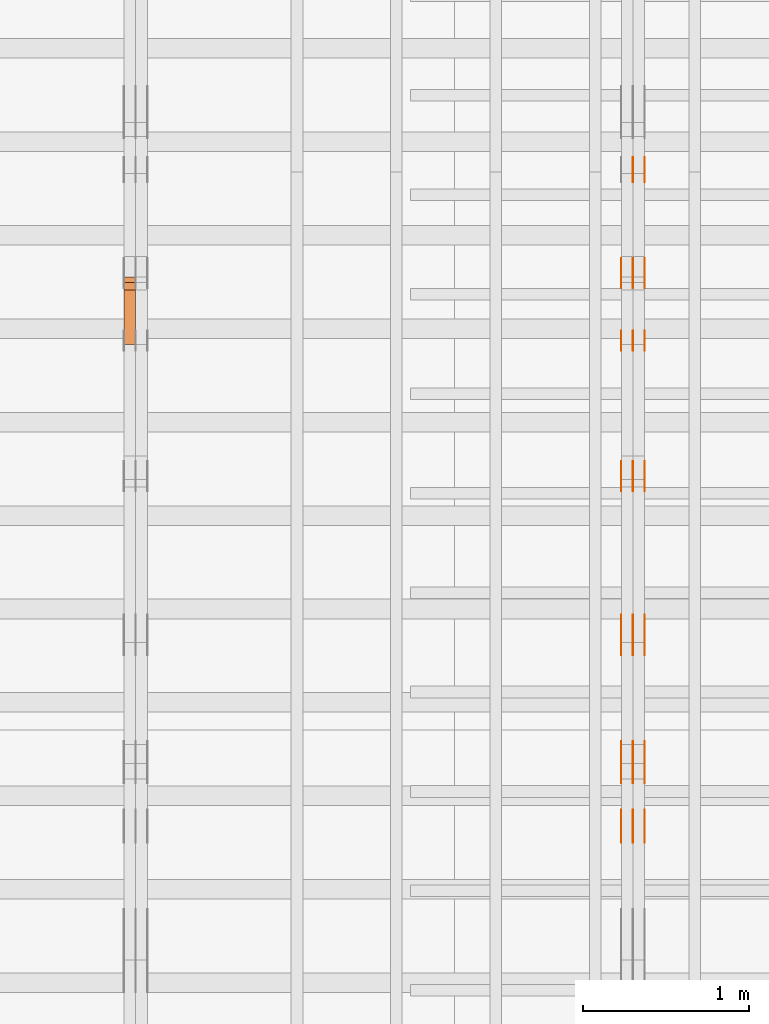
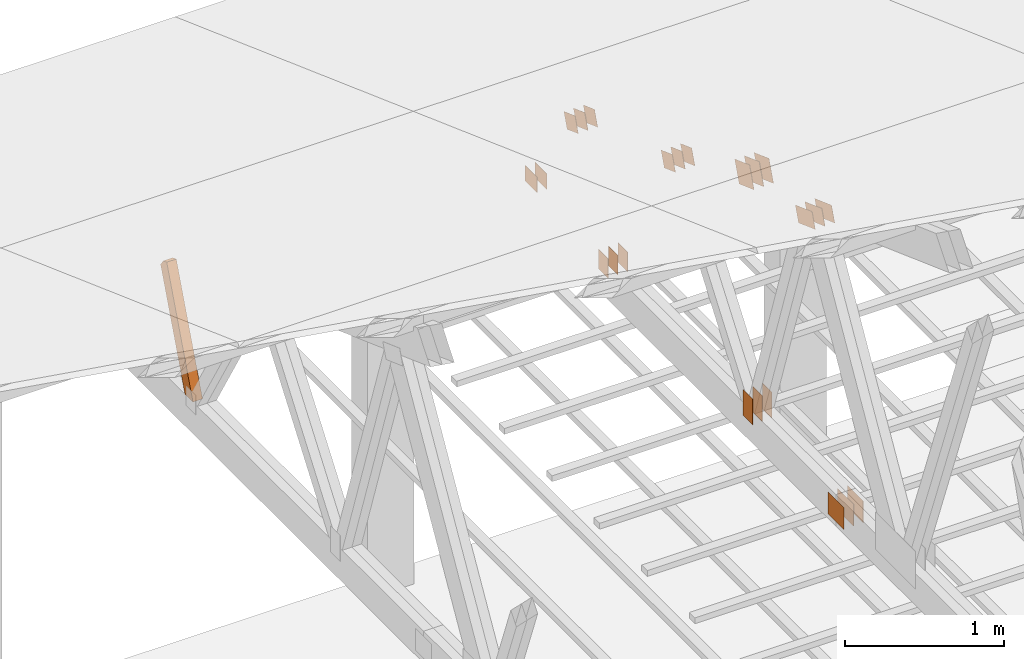
# One storey, part 170 of 189: 32 proxies.
"""IFC2X3 building model written with IfcOpenShell, lengths in millimetres."""

from ifc_helpers import new_model, entity, si_unit, converted_unit, derived_unit, direction, frame, frame_2d, origin, origin_2d_with_axis, place, context, subcontext, project, spatial, polyline, rectangle, outline, extrude, source, transform, mapped, material, type_object, type_shapes, element, save


model = new_model("IFC2X3")

# Units and contexts
model_context = context("Model", 3, precision=0.01, world=origin(), true_north=direction((6.12303176911189e-17, 1.0)))
body_context = subcontext(model_context, "Body", "Model", "MODEL_VIEW")
ifc_project = project(units=[si_unit("LENGTHUNIT", "METRE", prefix="MILLI"), si_unit("AREAUNIT", "SQUARE_METRE"), si_unit("VOLUMEUNIT", "CUBIC_METRE"), converted_unit("PLANEANGLEUNIT", "DEGREE", entity("IfcRatioMeasure", 0.0174532925199433), si_unit("PLANEANGLEUNIT", "RADIAN"), dimensions=[0, 0, 0, 0, 0, 0, 0]), si_unit("MASSUNIT", "GRAM", prefix="KILO"), derived_unit("MASSDENSITYUNIT", [(si_unit("MASSUNIT", "GRAM", prefix="KILO"), 1), (si_unit("LENGTHUNIT", "METRE"), -3)]), si_unit("TIMEUNIT", "SECOND"), si_unit("FREQUENCYUNIT", "HERTZ"), si_unit("THERMODYNAMICTEMPERATUREUNIT", "DEGREE_CELSIUS"), derived_unit("THERMALTRANSMITTANCEUNIT", [(si_unit("MASSUNIT", "GRAM", prefix="KILO"), 1), (si_unit("THERMODYNAMICTEMPERATUREUNIT", "KELVIN"), -1), (si_unit("TIMEUNIT", "SECOND"), -3)]), derived_unit("VOLUMETRICFLOWRATEUNIT", [(si_unit("LENGTHUNIT", "METRE"), 3), (si_unit("TIMEUNIT", "SECOND"), -1)]), si_unit("ELECTRICCURRENTUNIT", "AMPERE"), si_unit("ELECTRICVOLTAGEUNIT", "VOLT"), si_unit("POWERUNIT", "WATT"), si_unit("FORCEUNIT", "NEWTON"), si_unit("ILLUMINANCEUNIT", "LUX"), si_unit("LUMINOUSFLUXUNIT", "LUMEN"), si_unit("LUMINOUSINTENSITYUNIT", "CANDELA"), derived_unit("USERDEFINED", [(si_unit("MASSUNIT", "GRAM", prefix="KILO"), -1), (si_unit("LENGTHUNIT", "METRE"), -2), (si_unit("TIMEUNIT", "SECOND"), 3), (si_unit("LUMINOUSFLUXUNIT", "LUMEN"), 1)]), derived_unit("LINEARVELOCITYUNIT", [(si_unit("LENGTHUNIT", "METRE"), 1), (si_unit("TIMEUNIT", "SECOND"), -1)]), si_unit("PRESSUREUNIT", "PASCAL"), derived_unit("USERDEFINED", [(si_unit("LENGTHUNIT", "METRE"), -2), (si_unit("MASSUNIT", "GRAM", prefix="KILO"), 1), (si_unit("TIMEUNIT", "SECOND"), -2)])], contexts=[model_context])

# Site, building, storey
site_placement = place(None, origin())
site = spatial("IfcSite", under=ifc_project, at=site_placement, CompositionType="ELEMENT")
building_placement = place(site_placement, origin())
building = spatial("IfcBuilding", under=site, at=building_placement, CompositionType="ELEMENT")
storey_placement = place(building_placement, origin())
storey = spatial("IfcBuildingStorey", under=building, at=storey_placement, Name="Default", CompositionType="ELEMENT", Elevation=0.0)

# Proxies
ifc_material_1 = material(Name="IfcSurfaceStyle #248588")
building_element_proxy_type_1 = type_object("IfcBuildingElementProxyType", PredefinedType="NOTDEFINED", material=ifc_material_1)
shared_shape_1 = source(origin(), body_context, "Body", "SweptSolid", [
    extrude(outline(polyline([(-112.499846801582, -59.999986193028), (112.499924372729, -59.999986193028), (112.499888552087, 59.999986193028), (-112.499966123235, 59.999986193028), (-112.499846801582, -59.999986193028)])), frame((112.499989807712, 60.0001003787081, 0.0), z_axis=(0.0, 0.0, 1.0), x_axis=(-1.0, 0.0, 0.0)), (0.0, 0.0, 1.0), 1.3),
])
type_shapes(building_element_proxy_type_1, [shared_shape_1])
proxy_1_placement = place(building_placement, frame((45301.3, 24040.8868138992, 2049.61031693104), z_axis=(-1.0, 0.0, 0.0), x_axis=(0.0, -0.939692620785908, 0.342020143325669)))
element("IfcBuildingElementProxy", 1, at=proxy_1_placement, inside=storey, type_object=building_element_proxy_type_1, material=ifc_material_1, context=body_context, shape_type="MappedRepresentation", body=[
    mapped(shared_shape_1, transform((0.0, 0.0, 0.0), scale=1.0)),
])
ifc_material_2 = material(Name="IfcSurfaceStyle #248531")
building_element_proxy_type_2 = type_object("IfcBuildingElementProxyType", PredefinedType="NOTDEFINED", material=ifc_material_2)
shared_shape_2 = source(origin(), body_context, "Body", "SweptSolid", [
    extrude(outline(polyline([(-112.499846801582, -59.999986193028), (112.499924372729, -59.999986193028), (112.499888552087, 59.999986193028), (-112.499966123235, 59.999986193028), (-112.499846801582, -59.999986193028)])), frame((112.499989807712, 60.0001003787081, 0.0), z_axis=(0.0, 0.0, 1.0), x_axis=(-1.0, 0.0, 0.0)), (0.0, 0.0, 1.0), 1.29999999999998),
])
type_shapes(building_element_proxy_type_2, [shared_shape_2])
proxy_2_placement = place(building_placement, frame((45230.0, 24040.8868138992, 2049.61031693104), z_axis=(-1.0, 0.0, 0.0), x_axis=(0.0, -0.939692620785908, 0.342020143325669)))
element("IfcBuildingElementProxy", 2, at=proxy_2_placement, inside=storey, type_object=building_element_proxy_type_2, material=ifc_material_2, context=body_context, shape_type="MappedRepresentation", body=[
    mapped(shared_shape_2, transform((0.0, 0.0, 0.0), scale=1.0)),
])
ifc_material_3 = material(Name="IfcSurfaceStyle #248474")
building_element_proxy_type_3 = type_object("IfcBuildingElementProxyType", PredefinedType="NOTDEFINED", material=ifc_material_3)
shared_shape_3 = source(origin(), body_context, "Body", "SweptSolid", [
    extrude(outline(polyline([(-112.499846801582, -59.999986193028), (112.499924372729, -59.999986193028), (112.499888552087, 59.999986193028), (-112.499966123235, 59.999986193028), (-112.499846801582, -59.999986193028)])), frame((112.499989807712, 60.0001003787081, 0.0), z_axis=(0.0, 0.0, 1.0), x_axis=(-1.0, 0.0, 0.0)), (0.0, 0.0, 1.0), 1.29999999999998),
])
type_shapes(building_element_proxy_type_3, [shared_shape_3])
proxy_3_placement = place(building_placement, frame((45231.3, 24040.8868138992, 2049.61031693104), z_axis=(-1.0, 0.0, 0.0), x_axis=(0.0, -0.939692620785908, 0.342020143325669)))
element("IfcBuildingElementProxy", 3, at=proxy_3_placement, inside=storey, type_object=building_element_proxy_type_3, material=ifc_material_3, context=body_context, shape_type="MappedRepresentation", body=[
    mapped(shared_shape_3, transform((0.0, 0.0, 0.0), scale=1.0)),
])
ifc_material_4 = material(Name="IfcSurfaceStyle #248417")
building_element_proxy_type_4 = type_object("IfcBuildingElementProxyType", PredefinedType="NOTDEFINED", material=ifc_material_4)
shared_shape_4 = source(origin(), body_context, "Body", "SweptSolid", [
    extrude(outline(polyline([(-112.499846801582, -59.999986193028), (112.499924372729, -59.999986193028), (112.499888552087, 59.999986193028), (-112.499966123235, 59.999986193028), (-112.499846801582, -59.999986193028)])), frame((112.499989807712, 60.0001003787081, 0.0), z_axis=(0.0, 0.0, 1.0), x_axis=(-1.0, 0.0, 0.0)), (0.0, 0.0, 1.0), 1.29999999999999),
])
type_shapes(building_element_proxy_type_4, [shared_shape_4])
proxy_4_placement = place(building_placement, frame((45160.0, 24040.8868138992, 2049.61031693104), z_axis=(-1.0, 0.0, 0.0), x_axis=(0.0, -0.939692620785908, 0.342020143325669)))
element("IfcBuildingElementProxy", 4, at=proxy_4_placement, inside=storey, type_object=building_element_proxy_type_4, material=ifc_material_4, context=body_context, shape_type="MappedRepresentation", body=[
    mapped(shared_shape_4, transform((0.0, 0.0, 0.0), scale=1.0)),
])
ifc_material_5 = material(Name="IfcSurfaceStyle #248360")
building_element_proxy_type_5 = type_object("IfcBuildingElementProxyType", PredefinedType="NOTDEFINED", material=ifc_material_5)
shared_shape_5 = source(origin(), body_context, "Body", "SweptSolid", [
    extrude(rectangle(XDim=200.0, YDim=120.0, at=origin_2d_with_axis()), frame((100.0, 60.0002296775929, 0.0), z_axis=(0.0, 0.0, 1.0), x_axis=(-1.0, 0.0, 0.0)), (0.0, 0.0, 1.0), 1.3),
])
type_shapes(building_element_proxy_type_5, [shared_shape_5])
proxy_5_placement = place(building_placement, frame((45301.3, 24619.3435203224, 145.0), z_axis=(-1.0, 0.0, 0.0), x_axis=(0.0, 0.0, 1.0)))
element("IfcBuildingElementProxy", 5, at=proxy_5_placement, inside=storey, type_object=building_element_proxy_type_5, material=ifc_material_5, context=body_context, shape_type="MappedRepresentation", body=[
    mapped(shared_shape_5, transform((0.0, 0.0, 0.0), scale=1.0)),
])
ifc_material_6 = material(Name="IfcSurfaceStyle #248303")
building_element_proxy_type_6 = type_object("IfcBuildingElementProxyType", PredefinedType="NOTDEFINED", material=ifc_material_6)
shared_shape_6 = source(origin(), body_context, "Body", "SweptSolid", [
    extrude(rectangle(XDim=200.0, YDim=120.0, at=origin_2d_with_axis()), frame((100.0, 60.0002296775929, 0.0), z_axis=(0.0, 0.0, 1.0), x_axis=(-1.0, 0.0, 0.0)), (0.0, 0.0, 1.0), 1.29999999999998),
])
type_shapes(building_element_proxy_type_6, [shared_shape_6])
proxy_6_placement = place(building_placement, frame((45230.0, 24619.3435203224, 145.0), z_axis=(-1.0, 0.0, 0.0), x_axis=(0.0, 0.0, 1.0)))
element("IfcBuildingElementProxy", 6, at=proxy_6_placement, inside=storey, type_object=building_element_proxy_type_6, material=ifc_material_6, context=body_context, shape_type="MappedRepresentation", body=[
    mapped(shared_shape_6, transform((0.0, 0.0, 0.0), scale=1.0)),
])
ifc_material_7 = material(Name="IfcSurfaceStyle #248246")
building_element_proxy_type_7 = type_object("IfcBuildingElementProxyType", PredefinedType="NOTDEFINED", material=ifc_material_7)
shared_shape_7 = source(origin(), body_context, "Body", "SweptSolid", [
    extrude(rectangle(XDim=200.0, YDim=120.0, at=origin_2d_with_axis()), frame((100.0, 60.0002296775929, 0.0), z_axis=(0.0, 0.0, 1.0), x_axis=(-1.0, 0.0, 0.0)), (0.0, 0.0, 1.0), 1.29999999999998),
])
type_shapes(building_element_proxy_type_7, [shared_shape_7])
proxy_7_placement = place(building_placement, frame((45231.3, 24619.3435203224, 145.0), z_axis=(-1.0, 0.0, 0.0), x_axis=(0.0, 0.0, 1.0)))
element("IfcBuildingElementProxy", 7, at=proxy_7_placement, inside=storey, type_object=building_element_proxy_type_7, material=ifc_material_7, context=body_context, shape_type="MappedRepresentation", body=[
    mapped(shared_shape_7, transform((0.0, 0.0, 0.0), scale=1.0)),
])
ifc_material_8 = material(Name="IfcSurfaceStyle #248189")
building_element_proxy_type_8 = type_object("IfcBuildingElementProxyType", PredefinedType="NOTDEFINED", material=ifc_material_8)
shared_shape_8 = source(origin(), body_context, "Body", "SweptSolid", [
    extrude(rectangle(XDim=200.0, YDim=120.0, at=origin_2d_with_axis()), frame((100.0, 60.0002296775929, 0.0), z_axis=(0.0, 0.0, 1.0), x_axis=(-1.0, 0.0, 0.0)), (0.0, 0.0, 1.0), 1.29999999999999),
])
type_shapes(building_element_proxy_type_8, [shared_shape_8])
proxy_8_placement = place(building_placement, frame((45160.0, 24619.3435203224, 145.0), z_axis=(-1.0, 0.0, 0.0), x_axis=(0.0, 0.0, 1.0)))
element("IfcBuildingElementProxy", 8, at=proxy_8_placement, inside=storey, type_object=building_element_proxy_type_8, material=ifc_material_8, context=body_context, shape_type="MappedRepresentation", body=[
    mapped(shared_shape_8, transform((0.0, 0.0, 0.0), scale=1.0)),
])
ifc_material_9 = material(Name="IfcSurfaceStyle #247676")
building_element_proxy_type_9 = type_object("IfcBuildingElementProxyType", PredefinedType="NOTDEFINED", material=ifc_material_9)
shared_shape_9 = source(origin(), body_context, "Body", "SweptSolid", [
    extrude(outline(polyline([(-74.9999475298494, -60.0), (75.0000042257432, -60.0), (74.9999684051025, 60.0), (-75.0000251009963, 60.0), (-74.9999475298494, -60.0)])), frame((75.0000607644577, 60.0000865490217, 0.0), z_axis=(0.0, 0.0, 1.0), x_axis=(-1.0, 0.0, 0.0)), (0.0, 0.0, 1.0), 1.3),
])
type_shapes(building_element_proxy_type_9, [shared_shape_9])
proxy_9_placement = place(building_placement, frame((45301.3, 25732.0586805394, 1446.84420669249), z_axis=(-1.0, 0.0, 0.0), x_axis=(0.0, -0.939692620785908, 0.342020143325669)))
element("IfcBuildingElementProxy", 9, at=proxy_9_placement, inside=storey, type_object=building_element_proxy_type_9, material=ifc_material_9, context=body_context, shape_type="MappedRepresentation", body=[
    mapped(shared_shape_9, transform((0.0, 0.0, 0.0), scale=1.0)),
])
ifc_material_10 = material(Name="IfcSurfaceStyle #247619")
building_element_proxy_type_10 = type_object("IfcBuildingElementProxyType", PredefinedType="NOTDEFINED", material=ifc_material_10)
shared_shape_10 = source(origin(), body_context, "Body", "SweptSolid", [
    extrude(outline(polyline([(-74.9999475298494, -60.0), (75.0000042257432, -60.0), (74.9999684051025, 60.0), (-75.0000251009963, 60.0), (-74.9999475298494, -60.0)])), frame((75.0000607644577, 60.0000865490217, 0.0), z_axis=(0.0, 0.0, 1.0), x_axis=(-1.0, 0.0, 0.0)), (0.0, 0.0, 1.0), 1.29999999999999),
])
type_shapes(building_element_proxy_type_10, [shared_shape_10])
proxy_10_placement = place(building_placement, frame((45230.0, 25732.0586805394, 1446.84420669249), z_axis=(-1.0, 0.0, 0.0), x_axis=(0.0, -0.939692620785908, 0.342020143325669)))
element("IfcBuildingElementProxy", 10, at=proxy_10_placement, inside=storey, type_object=building_element_proxy_type_10, material=ifc_material_10, context=body_context, shape_type="MappedRepresentation", body=[
    mapped(shared_shape_10, transform((0.0, 0.0, 0.0), scale=1.0)),
])
ifc_material_11 = material(Name="IfcSurfaceStyle #247562")
building_element_proxy_type_11 = type_object("IfcBuildingElementProxyType", PredefinedType="NOTDEFINED", material=ifc_material_11)
shared_shape_11 = source(origin(), body_context, "Body", "SweptSolid", [
    extrude(outline(polyline([(-74.9999475298494, -60.0), (75.0000042257432, -60.0), (74.9999684051025, 60.0), (-75.0000251009963, 60.0), (-74.9999475298494, -60.0)])), frame((75.0000607644577, 60.0000865490217, 0.0), z_axis=(0.0, 0.0, 1.0), x_axis=(-1.0, 0.0, 0.0)), (0.0, 0.0, 1.0), 1.29999999999999),
])
type_shapes(building_element_proxy_type_11, [shared_shape_11])
proxy_11_placement = place(building_placement, frame((45231.3, 25732.0586805394, 1446.84420669249), z_axis=(-1.0, 0.0, 0.0), x_axis=(0.0, -0.939692620785908, 0.342020143325669)))
element("IfcBuildingElementProxy", 11, at=proxy_11_placement, inside=storey, type_object=building_element_proxy_type_11, material=ifc_material_11, context=body_context, shape_type="MappedRepresentation", body=[
    mapped(shared_shape_11, transform((0.0, 0.0, 0.0), scale=1.0)),
])
ifc_material_12 = material(Name="IfcSurfaceStyle #247505")
building_element_proxy_type_12 = type_object("IfcBuildingElementProxyType", PredefinedType="NOTDEFINED", material=ifc_material_12)
shared_shape_12 = source(origin(), body_context, "Body", "SweptSolid", [
    extrude(outline(polyline([(-74.9999475298494, -60.0), (75.0000042257432, -60.0), (74.9999684051025, 60.0), (-75.0000251009963, 60.0), (-74.9999475298494, -60.0)])), frame((75.0000607644577, 60.0000865490217, 0.0), z_axis=(0.0, 0.0, 1.0), x_axis=(-1.0, 0.0, 0.0)), (0.0, 0.0, 1.0), 1.29999999999999),
])
type_shapes(building_element_proxy_type_12, [shared_shape_12])
proxy_12_placement = place(building_placement, frame((45160.0, 25732.0586805394, 1446.84420669249), z_axis=(-1.0, 0.0, 0.0), x_axis=(0.0, -0.939692620785908, 0.342020143325669)))
element("IfcBuildingElementProxy", 12, at=proxy_12_placement, inside=storey, type_object=building_element_proxy_type_12, material=ifc_material_12, context=body_context, shape_type="MappedRepresentation", body=[
    mapped(shared_shape_12, transform((0.0, 0.0, 0.0), scale=1.0)),
])
ifc_material_13 = material(Name="IfcSurfaceStyle #247448")
building_element_proxy_type_13 = type_object("IfcBuildingElementProxyType", PredefinedType="NOTDEFINED", material=ifc_material_13)
shared_shape_13 = source(origin(), body_context, "Body", "SweptSolid", [
    extrude(rectangle(XDim=150.0, YDim=120.0, at=frame_2d((-7.105427357601e-15, 0.0), x_axis=(1.0, 0.0))), frame((75.0, 60.0, 0.0), z_axis=(0.0, 0.0, 1.0), x_axis=(-1.0, 0.0, 0.0)), (0.0, 0.0, 1.0), 1.3),
])
type_shapes(building_element_proxy_type_13, [shared_shape_13])
proxy_13_placement = place(building_placement, frame((45301.3, 26439.0083007813, 170.0), z_axis=(-1.0, 0.0, 0.0), x_axis=(0.0, 0.0, 1.0)))
element("IfcBuildingElementProxy", 13, at=proxy_13_placement, inside=storey, type_object=building_element_proxy_type_13, material=ifc_material_13, context=body_context, shape_type="MappedRepresentation", body=[
    mapped(shared_shape_13, transform((0.0, 0.0, 0.0), scale=1.0)),
])
ifc_material_14 = material(Name="IfcSurfaceStyle #247391")
building_element_proxy_type_14 = type_object("IfcBuildingElementProxyType", PredefinedType="NOTDEFINED", material=ifc_material_14)
shared_shape_14 = source(origin(), body_context, "Body", "SweptSolid", [
    extrude(rectangle(XDim=150.0, YDim=120.0, at=frame_2d((-7.105427357601e-15, 0.0), x_axis=(1.0, 0.0))), frame((75.0, 60.0, 0.0), z_axis=(0.0, 0.0, 1.0), x_axis=(-1.0, 0.0, 0.0)), (0.0, 0.0, 1.0), 1.29999999999999),
])
type_shapes(building_element_proxy_type_14, [shared_shape_14])
proxy_14_placement = place(building_placement, frame((45230.0, 26439.0083007813, 170.0), z_axis=(-1.0, 0.0, 0.0), x_axis=(0.0, 0.0, 1.0)))
element("IfcBuildingElementProxy", 14, at=proxy_14_placement, inside=storey, type_object=building_element_proxy_type_14, material=ifc_material_14, context=body_context, shape_type="MappedRepresentation", body=[
    mapped(shared_shape_14, transform((0.0, 0.0, 0.0), scale=1.0)),
])
ifc_material_15 = material(Name="IfcSurfaceStyle #247334")
building_element_proxy_type_15 = type_object("IfcBuildingElementProxyType", PredefinedType="NOTDEFINED", material=ifc_material_15)
shared_shape_15 = source(origin(), body_context, "Body", "SweptSolid", [
    extrude(rectangle(XDim=150.0, YDim=120.0, at=frame_2d((-7.105427357601e-15, 0.0), x_axis=(1.0, 0.0))), frame((75.0, 60.0, 0.0), z_axis=(0.0, 0.0, 1.0), x_axis=(-1.0, 0.0, 0.0)), (0.0, 0.0, 1.0), 1.29999999999999),
])
type_shapes(building_element_proxy_type_15, [shared_shape_15])
proxy_15_placement = place(building_placement, frame((45231.3, 26439.0083007813, 170.0), z_axis=(-1.0, 0.0, 0.0), x_axis=(0.0, 0.0, 1.0)))
element("IfcBuildingElementProxy", 15, at=proxy_15_placement, inside=storey, type_object=building_element_proxy_type_15, material=ifc_material_15, context=body_context, shape_type="MappedRepresentation", body=[
    mapped(shared_shape_15, transform((0.0, 0.0, 0.0), scale=1.0)),
])
ifc_material_16 = material(Name="IfcSurfaceStyle #247277")
building_element_proxy_type_16 = type_object("IfcBuildingElementProxyType", PredefinedType="NOTDEFINED", material=ifc_material_16)
shared_shape_16 = source(origin(), body_context, "Body", "SweptSolid", [
    extrude(rectangle(XDim=150.0, YDim=120.0, at=frame_2d((-7.105427357601e-15, 0.0), x_axis=(1.0, 0.0))), frame((75.0, 60.0, 0.0), z_axis=(0.0, 0.0, 1.0), x_axis=(-1.0, 0.0, 0.0)), (0.0, 0.0, 1.0), 1.29999999999999),
])
type_shapes(building_element_proxy_type_16, [shared_shape_16])
proxy_16_placement = place(building_placement, frame((45160.0, 26439.0083007813, 170.0), z_axis=(-1.0, 0.0, 0.0), x_axis=(0.0, 0.0, 1.0)))
element("IfcBuildingElementProxy", 16, at=proxy_16_placement, inside=storey, type_object=building_element_proxy_type_16, material=ifc_material_16, context=body_context, shape_type="MappedRepresentation", body=[
    mapped(shared_shape_16, transform((0.0, 0.0, 0.0), scale=1.0)),
])
ifc_material_17 = material(Name="IfcSurfaceStyle #246764")
building_element_proxy_type_17 = type_object("IfcBuildingElementProxyType", PredefinedType="NOTDEFINED", material=ifc_material_17)
shared_shape_17 = source(origin(), body_context, "Body", "SweptSolid", [
    extrude(outline(polyline([(-74.9999684051023, -60.0), (75.0000251009964, -60.0), (74.9999475298495, 60.0), (-75.0000042257435, 60.0), (-74.9999684051023, -60.0)])), frame((75.0000251009964, 60.0000006265238, 0.0), z_axis=(0.0, 0.0, 1.0), x_axis=(-1.0, 0.0, 0.0)), (0.0, 0.0, 1.0), 1.3),
])
type_shapes(building_element_proxy_type_17, [shared_shape_17])
proxy_17_placement = place(building_placement, frame((45301.3, 26956.490053282, 1001.18769055967), z_axis=(-1.0, 0.0, 0.0), x_axis=(0.0, -0.939692620785908, 0.342020143325669)))
element("IfcBuildingElementProxy", 17, at=proxy_17_placement, inside=storey, type_object=building_element_proxy_type_17, material=ifc_material_17, context=body_context, shape_type="MappedRepresentation", body=[
    mapped(shared_shape_17, transform((0.0, 0.0, 0.0), scale=1.0)),
])
ifc_material_18 = material(Name="IfcSurfaceStyle #246707")
building_element_proxy_type_18 = type_object("IfcBuildingElementProxyType", PredefinedType="NOTDEFINED", material=ifc_material_18)
shared_shape_18 = source(origin(), body_context, "Body", "SweptSolid", [
    extrude(outline(polyline([(-74.9999684051023, -60.0), (75.0000251009964, -60.0), (74.9999475298495, 60.0), (-75.0000042257435, 60.0), (-74.9999684051023, -60.0)])), frame((75.0000251009964, 60.0000006265238, 0.0), z_axis=(0.0, 0.0, 1.0), x_axis=(-1.0, 0.0, 0.0)), (0.0, 0.0, 1.0), 1.29999999999999),
])
type_shapes(building_element_proxy_type_18, [shared_shape_18])
proxy_18_placement = place(building_placement, frame((45230.0, 26956.490053282, 1001.18769055967), z_axis=(-1.0, 0.0, 0.0), x_axis=(0.0, -0.939692620785908, 0.342020143325669)))
element("IfcBuildingElementProxy", 18, at=proxy_18_placement, inside=storey, type_object=building_element_proxy_type_18, material=ifc_material_18, context=body_context, shape_type="MappedRepresentation", body=[
    mapped(shared_shape_18, transform((0.0, 0.0, 0.0), scale=1.0)),
])
ifc_material_19 = material(Name="IfcSurfaceStyle #246650")
building_element_proxy_type_19 = type_object("IfcBuildingElementProxyType", PredefinedType="NOTDEFINED", material=ifc_material_19)
shared_shape_19 = source(origin(), body_context, "Body", "SweptSolid", [
    extrude(outline(polyline([(-74.9999684051023, -60.0), (75.0000251009964, -60.0), (74.9999475298495, 60.0), (-75.0000042257435, 60.0), (-74.9999684051023, -60.0)])), frame((75.0000251009964, 60.0000006265238, 0.0), z_axis=(0.0, 0.0, 1.0), x_axis=(-1.0, 0.0, 0.0)), (0.0, 0.0, 1.0), 1.29999999999999),
])
type_shapes(building_element_proxy_type_19, [shared_shape_19])
proxy_19_placement = place(building_placement, frame((45231.3, 26956.490053282, 1001.18769055967), z_axis=(-1.0, 0.0, 0.0), x_axis=(0.0, -0.939692620785908, 0.342020143325669)))
element("IfcBuildingElementProxy", 19, at=proxy_19_placement, inside=storey, type_object=building_element_proxy_type_19, material=ifc_material_19, context=body_context, shape_type="MappedRepresentation", body=[
    mapped(shared_shape_19, transform((0.0, 0.0, 0.0), scale=1.0)),
])
ifc_material_20 = material(Name="IfcSurfaceStyle #246593")
building_element_proxy_type_20 = type_object("IfcBuildingElementProxyType", PredefinedType="NOTDEFINED", material=ifc_material_20)
shared_shape_20 = source(origin(), body_context, "Body", "SweptSolid", [
    extrude(outline(polyline([(-74.9999684051023, -60.0), (75.0000251009964, -60.0), (74.9999475298495, 60.0), (-75.0000042257435, 60.0), (-74.9999684051023, -60.0)])), frame((75.0000251009964, 60.0000006265238, 0.0), z_axis=(0.0, 0.0, 1.0), x_axis=(-1.0, 0.0, 0.0)), (0.0, 0.0, 1.0), 1.29999999999999),
])
type_shapes(building_element_proxy_type_20, [shared_shape_20])
proxy_20_placement = place(building_placement, frame((45160.0, 26956.490053282, 1001.18769055967), z_axis=(-1.0, 0.0, 0.0), x_axis=(0.0, -0.939692620785908, 0.342020143325669)))
element("IfcBuildingElementProxy", 20, at=proxy_20_placement, inside=storey, type_object=building_element_proxy_type_20, material=ifc_material_20, context=body_context, shape_type="MappedRepresentation", body=[
    mapped(shared_shape_20, transform((0.0, 0.0, 0.0), scale=1.0)),
])
ifc_material_21 = material(Name="IfcSurfaceStyle #246536")
building_element_proxy_type_21 = type_object("IfcBuildingElementProxyType", PredefinedType="NOTDEFINED", material=ifc_material_21)
shared_shape_21 = source(origin(), body_context, "Body", "SweptSolid", [
    extrude(rectangle(XDim=150.0, YDim=120.0, at=origin_2d_with_axis()), frame((75.0, 60.0, 0.0), z_axis=(0.0, 0.0, 1.0), x_axis=(-1.0, 0.0, 0.0)), (0.0, 0.0, 1.0), 1.3),
])
type_shapes(building_element_proxy_type_21, [shared_shape_21])
proxy_21_placement = place(building_placement, frame((45301.3, 27607.3129882813, 185.0), z_axis=(-1.0, 0.0, 0.0), x_axis=(0.0, -1.0, 0.0)))
element("IfcBuildingElementProxy", 21, at=proxy_21_placement, inside=storey, type_object=building_element_proxy_type_21, material=ifc_material_21, context=body_context, shape_type="MappedRepresentation", body=[
    mapped(shared_shape_21, transform((0.0, 0.0, 0.0), scale=1.0)),
])
ifc_material_22 = material(Name="IfcSurfaceStyle #246479")
building_element_proxy_type_22 = type_object("IfcBuildingElementProxyType", PredefinedType="NOTDEFINED", material=ifc_material_22)
shared_shape_22 = source(origin(), body_context, "Body", "SweptSolid", [
    extrude(rectangle(XDim=150.0, YDim=120.0, at=origin_2d_with_axis()), frame((75.0, 60.0, 0.0), z_axis=(0.0, 0.0, 1.0), x_axis=(-1.0, 0.0, 0.0)), (0.0, 0.0, 1.0), 1.29999999999999),
])
type_shapes(building_element_proxy_type_22, [shared_shape_22])
proxy_22_placement = place(building_placement, frame((45230.0, 27607.3129882813, 185.0), z_axis=(-1.0, 0.0, 0.0), x_axis=(0.0, -1.0, 0.0)))
element("IfcBuildingElementProxy", 22, at=proxy_22_placement, inside=storey, type_object=building_element_proxy_type_22, material=ifc_material_22, context=body_context, shape_type="MappedRepresentation", body=[
    mapped(shared_shape_22, transform((0.0, 0.0, 0.0), scale=1.0)),
])
ifc_material_23 = material(Name="IfcSurfaceStyle #246422")
building_element_proxy_type_23 = type_object("IfcBuildingElementProxyType", PredefinedType="NOTDEFINED", material=ifc_material_23)
shared_shape_23 = source(origin(), body_context, "Body", "SweptSolid", [
    extrude(rectangle(XDim=150.0, YDim=120.0, at=origin_2d_with_axis()), frame((75.0, 60.0, 0.0), z_axis=(0.0, 0.0, 1.0), x_axis=(-1.0, 0.0, 0.0)), (0.0, 0.0, 1.0), 1.29999999999999),
])
type_shapes(building_element_proxy_type_23, [shared_shape_23])
proxy_23_placement = place(building_placement, frame((45231.3, 27607.3129882813, 185.0), z_axis=(-1.0, 0.0, 0.0), x_axis=(0.0, -1.0, 0.0)))
element("IfcBuildingElementProxy", 23, at=proxy_23_placement, inside=storey, type_object=building_element_proxy_type_23, material=ifc_material_23, context=body_context, shape_type="MappedRepresentation", body=[
    mapped(shared_shape_23, transform((0.0, 0.0, 0.0), scale=1.0)),
])
ifc_material_24 = material(Name="IfcSurfaceStyle #244712")
building_element_proxy_type_24 = type_object("IfcBuildingElementProxyType", PredefinedType="NOTDEFINED", material=ifc_material_24)
shared_shape_24 = source(origin(), body_context, "Body", "SweptSolid", [
    extrude(rectangle(XDim=200.0, YDim=168.0, at=origin_2d_with_axis()), frame((100.0, 84.0, 0.0), z_axis=(0.0, 0.0, 1.0), x_axis=(-1.0, 0.0, 0.0)), (0.0, 0.0, 1.0), 1.3),
])
type_shapes(building_element_proxy_type_24, [shared_shape_24])
proxy_24_placement = place(building_placement, frame((45301.3, 23470.0, 206.5), z_axis=(-1.0, 0.0, 0.0), x_axis=(0.0, 1.0, 0.0)))
element("IfcBuildingElementProxy", 24, at=proxy_24_placement, inside=storey, type_object=building_element_proxy_type_24, material=ifc_material_24, context=body_context, shape_type="MappedRepresentation", body=[
    mapped(shared_shape_24, transform((0.0, 0.0, 0.0), scale=1.0)),
])
ifc_material_25 = material(Name="IfcSurfaceStyle #244655")
building_element_proxy_type_25 = type_object("IfcBuildingElementProxyType", PredefinedType="NOTDEFINED", material=ifc_material_25)
shared_shape_25 = source(origin(), body_context, "Body", "SweptSolid", [
    extrude(rectangle(XDim=200.0, YDim=168.0, at=origin_2d_with_axis()), frame((100.0, 84.0, 0.0), z_axis=(0.0, 0.0, 1.0), x_axis=(-1.0, 0.0, 0.0)), (0.0, 0.0, 1.0), 1.29999999999998),
])
type_shapes(building_element_proxy_type_25, [shared_shape_25])
proxy_25_placement = place(building_placement, frame((45230.0, 23470.0, 206.5), z_axis=(-1.0, 0.0, 0.0), x_axis=(0.0, 1.0, 0.0)))
element("IfcBuildingElementProxy", 25, at=proxy_25_placement, inside=storey, type_object=building_element_proxy_type_25, material=ifc_material_25, context=body_context, shape_type="MappedRepresentation", body=[
    mapped(shared_shape_25, transform((0.0, 0.0, 0.0), scale=1.0)),
])
ifc_material_26 = material(Name="IfcSurfaceStyle #244598")
building_element_proxy_type_26 = type_object("IfcBuildingElementProxyType", PredefinedType="NOTDEFINED", material=ifc_material_26)
shared_shape_26 = source(origin(), body_context, "Body", "SweptSolid", [
    extrude(rectangle(XDim=200.0, YDim=168.0, at=origin_2d_with_axis()), frame((100.0, 84.0, 0.0), z_axis=(0.0, 0.0, 1.0), x_axis=(-1.0, 0.0, 0.0)), (0.0, 0.0, 1.0), 1.29999999999998),
])
type_shapes(building_element_proxy_type_26, [shared_shape_26])
proxy_26_placement = place(building_placement, frame((45231.3, 23470.0, 206.5), z_axis=(-1.0, 0.0, 0.0), x_axis=(0.0, 1.0, 0.0)))
element("IfcBuildingElementProxy", 26, at=proxy_26_placement, inside=storey, type_object=building_element_proxy_type_26, material=ifc_material_26, context=body_context, shape_type="MappedRepresentation", body=[
    mapped(shared_shape_26, transform((0.0, 0.0, 0.0), scale=1.0)),
])
ifc_material_27 = material(Name="IfcSurfaceStyle #244541")
building_element_proxy_type_27 = type_object("IfcBuildingElementProxyType", PredefinedType="NOTDEFINED", material=ifc_material_27)
shared_shape_27 = source(origin(), body_context, "Body", "SweptSolid", [
    extrude(rectangle(XDim=200.0, YDim=168.0, at=origin_2d_with_axis()), frame((100.0, 84.0, 0.0), z_axis=(0.0, 0.0, 1.0), x_axis=(-1.0, 0.0, 0.0)), (0.0, 0.0, 1.0), 1.29999999999999),
])
type_shapes(building_element_proxy_type_27, [shared_shape_27])
proxy_27_placement = place(building_placement, frame((45160.0, 23470.0, 206.5), z_axis=(-1.0, 0.0, 0.0), x_axis=(0.0, 1.0, 0.0)))
element("IfcBuildingElementProxy", 27, at=proxy_27_placement, inside=storey, type_object=building_element_proxy_type_27, material=ifc_material_27, context=body_context, shape_type="MappedRepresentation", body=[
    mapped(shared_shape_27, transform((0.0, 0.0, 0.0), scale=1.0)),
])
ifc_material_28 = material(Name="IfcSurfaceStyle #242552")
building_element_proxy_type_28 = type_object("IfcBuildingElementProxyType", PredefinedType="NOTDEFINED", material=ifc_material_28)
shared_shape_28 = source(origin(), body_context, "Body", "SweptSolid", [
    extrude(outline(polyline([(-99.9999065788418, -84.0000755647729), (99.9999734279406, -84.0000755647729), (99.9999483293475, 84.000075564773), (-100.000015178446, 84.000075564773), (-99.9999065788418, -84.0000755647729)])), frame((100.000157783747, 84.0001144608011, 0.0), z_axis=(0.0, 0.0, 1.0), x_axis=(-1.0, 0.0, 0.0)), (0.0, 0.0, 1.0), 1.3),
])
type_shapes(building_element_proxy_type_28, [shared_shape_28])
proxy_28_placement = place(building_placement, frame((45301.3, 24788.4767593228, 1895.10136879206), z_axis=(-1.0, 0.0, 0.0), x_axis=(0.0, -0.939692620785908, 0.342020143325669)))
element("IfcBuildingElementProxy", 28, at=proxy_28_placement, inside=storey, type_object=building_element_proxy_type_28, material=ifc_material_28, context=body_context, shape_type="MappedRepresentation", body=[
    mapped(shared_shape_28, transform((0.0, 0.0, 0.0), scale=1.0)),
])
ifc_material_29 = material(Name="IfcSurfaceStyle #242495")
building_element_proxy_type_29 = type_object("IfcBuildingElementProxyType", PredefinedType="NOTDEFINED", material=ifc_material_29)
shared_shape_29 = source(origin(), body_context, "Body", "SweptSolid", [
    extrude(outline(polyline([(-99.9999065788418, -84.0000755647729), (99.9999734279406, -84.0000755647729), (99.9999483293475, 84.000075564773), (-100.000015178446, 84.000075564773), (-99.9999065788418, -84.0000755647729)])), frame((100.000157783747, 84.0001144608011, 0.0), z_axis=(0.0, 0.0, 1.0), x_axis=(-1.0, 0.0, 0.0)), (0.0, 0.0, 1.0), 1.29999999999998),
])
type_shapes(building_element_proxy_type_29, [shared_shape_29])
proxy_29_placement = place(building_placement, frame((45230.0, 24788.4767593228, 1895.10136879206), z_axis=(-1.0, 0.0, 0.0), x_axis=(0.0, -0.939692620785908, 0.342020143325669)))
element("IfcBuildingElementProxy", 29, at=proxy_29_placement, inside=storey, type_object=building_element_proxy_type_29, material=ifc_material_29, context=body_context, shape_type="MappedRepresentation", body=[
    mapped(shared_shape_29, transform((0.0, 0.0, 0.0), scale=1.0)),
])
ifc_material_30 = material(Name="IfcSurfaceStyle #242438")
building_element_proxy_type_30 = type_object("IfcBuildingElementProxyType", PredefinedType="NOTDEFINED", material=ifc_material_30)
shared_shape_30 = source(origin(), body_context, "Body", "SweptSolid", [
    extrude(outline(polyline([(-99.9999065788418, -84.0000755647729), (99.9999734279406, -84.0000755647729), (99.9999483293475, 84.000075564773), (-100.000015178446, 84.000075564773), (-99.9999065788418, -84.0000755647729)])), frame((100.000157783747, 84.0001144608011, 0.0), z_axis=(0.0, 0.0, 1.0), x_axis=(-1.0, 0.0, 0.0)), (0.0, 0.0, 1.0), 1.29999999999998),
])
type_shapes(building_element_proxy_type_30, [shared_shape_30])
proxy_30_placement = place(building_placement, frame((45231.3, 24788.4767593228, 1895.10136879206), z_axis=(-1.0, 0.0, 0.0), x_axis=(0.0, -0.939692620785908, 0.342020143325669)))
element("IfcBuildingElementProxy", 30, at=proxy_30_placement, inside=storey, type_object=building_element_proxy_type_30, material=ifc_material_30, context=body_context, shape_type="MappedRepresentation", body=[
    mapped(shared_shape_30, transform((0.0, 0.0, 0.0), scale=1.0)),
])
ifc_material_31 = material(Name="IfcSurfaceStyle #242381")
building_element_proxy_type_31 = type_object("IfcBuildingElementProxyType", PredefinedType="NOTDEFINED", material=ifc_material_31)
shared_shape_31 = source(origin(), body_context, "Body", "SweptSolid", [
    extrude(outline(polyline([(-99.9999065788418, -84.0000755647729), (99.9999734279406, -84.0000755647729), (99.9999483293475, 84.000075564773), (-100.000015178446, 84.000075564773), (-99.9999065788418, -84.0000755647729)])), frame((100.000157783747, 84.0001144608011, 0.0), z_axis=(0.0, 0.0, 1.0), x_axis=(-1.0, 0.0, 0.0)), (0.0, 0.0, 1.0), 1.29999999999999),
])
type_shapes(building_element_proxy_type_31, [shared_shape_31])
proxy_31_placement = place(building_placement, frame((45160.0, 24788.4767593228, 1895.10136879206), z_axis=(-1.0, 0.0, 0.0), x_axis=(0.0, -0.939692620785908, 0.342020143325669)))
element("IfcBuildingElementProxy", 31, at=proxy_31_placement, inside=storey, type_object=building_element_proxy_type_31, material=ifc_material_31, context=body_context, shape_type="MappedRepresentation", body=[
    mapped(shared_shape_31, transform((0.0, 0.0, 0.0), scale=1.0)),
])
ifc_material_32 = material(Name="IfcSurfaceStyle #223432")
building_element_proxy_type_32 = type_object("IfcBuildingElementProxyType", Name="T1-W14 223430", PredefinedType="NOTDEFINED", material=ifc_material_32)
shared_shape_32 = source(origin(), body_context, "Body", "SweptSolid", [
    extrude(outline(polyline([(-561.981237417233, -47.499947472121), (373.092610496013, -47.499947472121), (373.679602940405, -4.61719047935016e-05), (341.277449358876, 47.4999705580734), (-526.068425378061, 47.4999705580734), (-561.981237417233, -47.499947472121)])), frame((373.679632439416, 47.500120814091, 0.0), z_axis=(0.0, 0.0, 1.0), x_axis=(-1.0, 0.0, 0.0)), (0.0, 0.0, 1.0), 69.9999999999999),
])
type_shapes(building_element_proxy_type_32, [shared_shape_32])
proxy_32_placement = place(building_placement, frame((42230.0, 26895.4809555667, 1086.61918844835), z_axis=(-1.0, 0.0, 0.0), x_axis=(0.0, -0.353606472447933, -0.935394281916951)))
element("IfcBuildingElementProxy", 32, at=proxy_32_placement, inside=storey, type_object=building_element_proxy_type_32, material=ifc_material_32, Name="T1-W14", context=body_context, shape_type="MappedRepresentation", body=[
    mapped(shared_shape_32, transform((0.0, 0.0, 0.0), scale=1.0)),
])

save(model, "model.ifc")
